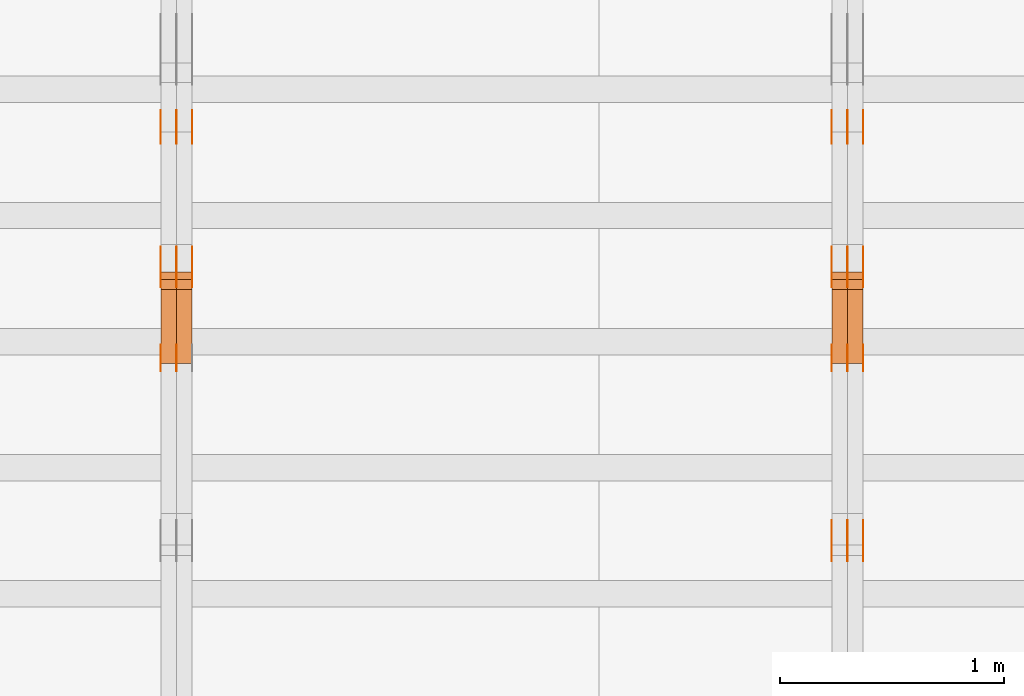
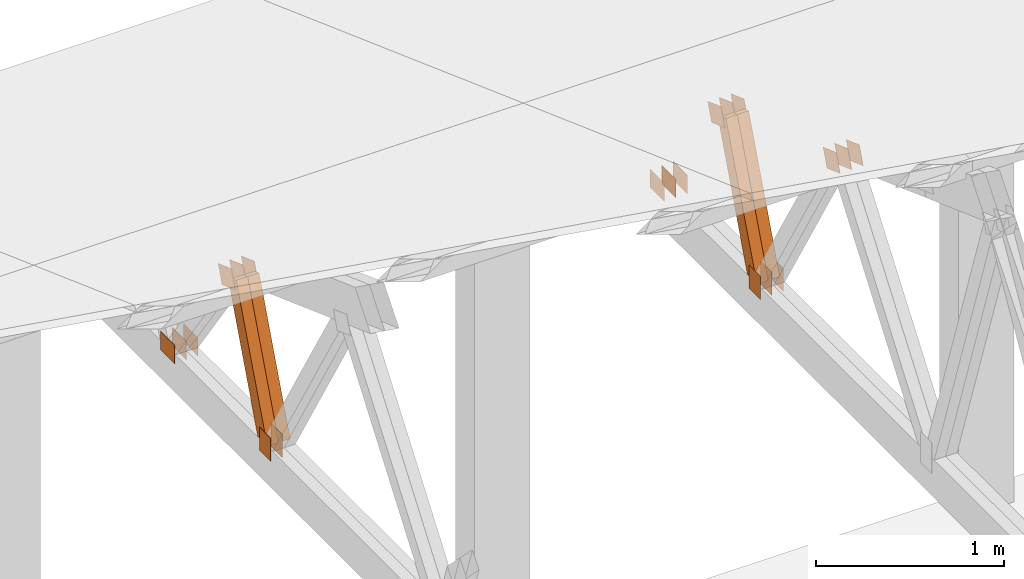
# One storey, part 113 of 189: 31 proxies.
"""IFC2X3 building model written with IfcOpenShell, lengths in millimetres."""

from ifc_helpers import new_model, entity, si_unit, converted_unit, derived_unit, direction, frame, frame_2d, origin, origin_2d_with_axis, place, context, subcontext, project, spatial, polyline, rectangle, outline, extrude, source, transform, mapped, material, type_object, type_shapes, element, save


model = new_model("IFC2X3")

# Units and contexts
model_context = context("Model", 3, precision=0.01, world=origin(), true_north=direction((6.12303176911189e-17, 1.0)))
body_context = subcontext(model_context, "Body", "Model", "MODEL_VIEW")
ifc_project = project(units=[si_unit("LENGTHUNIT", "METRE", prefix="MILLI"), si_unit("AREAUNIT", "SQUARE_METRE"), si_unit("VOLUMEUNIT", "CUBIC_METRE"), converted_unit("PLANEANGLEUNIT", "DEGREE", entity("IfcRatioMeasure", 0.0174532925199433), si_unit("PLANEANGLEUNIT", "RADIAN"), dimensions=[0, 0, 0, 0, 0, 0, 0]), si_unit("MASSUNIT", "GRAM", prefix="KILO"), derived_unit("MASSDENSITYUNIT", [(si_unit("MASSUNIT", "GRAM", prefix="KILO"), 1), (si_unit("LENGTHUNIT", "METRE"), -3)]), si_unit("TIMEUNIT", "SECOND"), si_unit("FREQUENCYUNIT", "HERTZ"), si_unit("THERMODYNAMICTEMPERATUREUNIT", "DEGREE_CELSIUS"), derived_unit("THERMALTRANSMITTANCEUNIT", [(si_unit("MASSUNIT", "GRAM", prefix="KILO"), 1), (si_unit("THERMODYNAMICTEMPERATUREUNIT", "KELVIN"), -1), (si_unit("TIMEUNIT", "SECOND"), -3)]), derived_unit("VOLUMETRICFLOWRATEUNIT", [(si_unit("LENGTHUNIT", "METRE"), 3), (si_unit("TIMEUNIT", "SECOND"), -1)]), si_unit("ELECTRICCURRENTUNIT", "AMPERE"), si_unit("ELECTRICVOLTAGEUNIT", "VOLT"), si_unit("POWERUNIT", "WATT"), si_unit("FORCEUNIT", "NEWTON"), si_unit("ILLUMINANCEUNIT", "LUX"), si_unit("LUMINOUSFLUXUNIT", "LUMEN"), si_unit("LUMINOUSINTENSITYUNIT", "CANDELA"), derived_unit("USERDEFINED", [(si_unit("MASSUNIT", "GRAM", prefix="KILO"), -1), (si_unit("LENGTHUNIT", "METRE"), -2), (si_unit("TIMEUNIT", "SECOND"), 3), (si_unit("LUMINOUSFLUXUNIT", "LUMEN"), 1)]), derived_unit("LINEARVELOCITYUNIT", [(si_unit("LENGTHUNIT", "METRE"), 1), (si_unit("TIMEUNIT", "SECOND"), -1)]), si_unit("PRESSUREUNIT", "PASCAL"), derived_unit("USERDEFINED", [(si_unit("LENGTHUNIT", "METRE"), -2), (si_unit("MASSUNIT", "GRAM", prefix="KILO"), 1), (si_unit("TIMEUNIT", "SECOND"), -2)])], contexts=[model_context])

# Site, building, storey
site_placement = place(None, origin())
site = spatial("IfcSite", under=ifc_project, at=site_placement, CompositionType="ELEMENT")
building_placement = place(site_placement, origin())
building = spatial("IfcBuilding", under=site, at=building_placement, CompositionType="ELEMENT")
storey_placement = place(building_placement, origin())
storey = spatial("IfcBuildingStorey", under=building, at=storey_placement, Name="Default", CompositionType="ELEMENT", Elevation=0.0)

# Proxies
ifc_material_1 = material(Name="IfcSurfaceStyle #42406")
building_element_proxy_type_1 = type_object("IfcBuildingElementProxyType", PredefinedType="NOTDEFINED", material=ifc_material_1)
shared_shape_1 = source(origin(), body_context, "Body", "SweptSolid", [
    extrude(outline(polyline([(-74.9999475298494, -60.0), (75.0000042257432, -60.0), (74.9999684051025, 60.0), (-75.0000251009963, 60.0), (-74.9999475298494, -60.0)])), frame((75.0000607644577, 60.0000865490217, 0.0), z_axis=(0.0, 0.0, 1.0), x_axis=(-1.0, 0.0, 0.0)), (0.0, 0.0, 1.0), 1.3),
])
type_shapes(building_element_proxy_type_1, [shared_shape_1])
proxy_1_placement = place(building_placement, frame((6336.3, 25732.0586805394, 1446.84420669249), z_axis=(-1.0, 0.0, 0.0), x_axis=(0.0, -0.939692620785908, 0.342020143325669)))
element("IfcBuildingElementProxy", 1, at=proxy_1_placement, inside=storey, type_object=building_element_proxy_type_1, material=ifc_material_1, context=body_context, shape_type="MappedRepresentation", body=[
    mapped(shared_shape_1, transform((0.0, 0.0, 0.0), scale=1.0)),
])
ifc_material_2 = material(Name="IfcSurfaceStyle #42349")
building_element_proxy_type_2 = type_object("IfcBuildingElementProxyType", PredefinedType="NOTDEFINED", material=ifc_material_2)
shared_shape_2 = source(origin(), body_context, "Body", "SweptSolid", [
    extrude(outline(polyline([(-74.9999475298494, -60.0), (75.0000042257432, -60.0), (74.9999684051025, 60.0), (-75.0000251009963, 60.0), (-74.9999475298494, -60.0)])), frame((75.0000607644577, 60.0000865490217, 0.0), z_axis=(0.0, 0.0, 1.0), x_axis=(-1.0, 0.0, 0.0)), (0.0, 0.0, 1.0), 1.29999999999999),
])
type_shapes(building_element_proxy_type_2, [shared_shape_2])
proxy_2_placement = place(building_placement, frame((6265.0, 25732.0586805394, 1446.84420669249), z_axis=(-1.0, 0.0, 0.0), x_axis=(0.0, -0.939692620785908, 0.342020143325669)))
element("IfcBuildingElementProxy", 2, at=proxy_2_placement, inside=storey, type_object=building_element_proxy_type_2, material=ifc_material_2, context=body_context, shape_type="MappedRepresentation", body=[
    mapped(shared_shape_2, transform((0.0, 0.0, 0.0), scale=1.0)),
])
ifc_material_3 = material(Name="IfcSurfaceStyle #42292")
building_element_proxy_type_3 = type_object("IfcBuildingElementProxyType", PredefinedType="NOTDEFINED", material=ifc_material_3)
shared_shape_3 = source(origin(), body_context, "Body", "SweptSolid", [
    extrude(outline(polyline([(-74.9999475298494, -60.0), (75.0000042257432, -60.0), (74.9999684051025, 60.0), (-75.0000251009963, 60.0), (-74.9999475298494, -60.0)])), frame((75.0000607644577, 60.0000865490217, 0.0), z_axis=(0.0, 0.0, 1.0), x_axis=(-1.0, 0.0, 0.0)), (0.0, 0.0, 1.0), 1.29999999999999),
])
type_shapes(building_element_proxy_type_3, [shared_shape_3])
proxy_3_placement = place(building_placement, frame((6266.3, 25732.0586805394, 1446.84420669249), z_axis=(-1.0, 0.0, 0.0), x_axis=(0.0, -0.939692620785908, 0.342020143325669)))
element("IfcBuildingElementProxy", 3, at=proxy_3_placement, inside=storey, type_object=building_element_proxy_type_3, material=ifc_material_3, context=body_context, shape_type="MappedRepresentation", body=[
    mapped(shared_shape_3, transform((0.0, 0.0, 0.0), scale=1.0)),
])
ifc_material_4 = material(Name="IfcSurfaceStyle #42235")
building_element_proxy_type_4 = type_object("IfcBuildingElementProxyType", PredefinedType="NOTDEFINED", material=ifc_material_4)
shared_shape_4 = source(origin(), body_context, "Body", "SweptSolid", [
    extrude(outline(polyline([(-74.9999475298494, -60.0), (75.0000042257432, -60.0), (74.9999684051025, 60.0), (-75.0000251009963, 60.0), (-74.9999475298494, -60.0)])), frame((75.0000607644577, 60.0000865490217, 0.0), z_axis=(0.0, 0.0, 1.0), x_axis=(-1.0, 0.0, 0.0)), (0.0, 0.0, 1.0), 1.29999999999999),
])
type_shapes(building_element_proxy_type_4, [shared_shape_4])
proxy_4_placement = place(building_placement, frame((6195.0, 25732.0586805394, 1446.84420669249), z_axis=(-1.0, 0.0, 0.0), x_axis=(0.0, -0.939692620785908, 0.342020143325669)))
element("IfcBuildingElementProxy", 4, at=proxy_4_placement, inside=storey, type_object=building_element_proxy_type_4, material=ifc_material_4, context=body_context, shape_type="MappedRepresentation", body=[
    mapped(shared_shape_4, transform((0.0, 0.0, 0.0), scale=1.0)),
])
ifc_material_5 = material(Name="IfcSurfaceStyle #42178")
building_element_proxy_type_5 = type_object("IfcBuildingElementProxyType", PredefinedType="NOTDEFINED", material=ifc_material_5)
shared_shape_5 = source(origin(), body_context, "Body", "SweptSolid", [
    extrude(rectangle(XDim=150.0, YDim=120.0, at=frame_2d((-7.105427357601e-15, 0.0), x_axis=(1.0, 0.0))), frame((75.0, 60.0, 0.0), z_axis=(0.0, 0.0, 1.0), x_axis=(-1.0, 0.0, 0.0)), (0.0, 0.0, 1.0), 1.3),
])
type_shapes(building_element_proxy_type_5, [shared_shape_5])
proxy_5_placement = place(building_placement, frame((6336.3, 26439.0083007813, 170.0), z_axis=(-1.0, 0.0, 0.0), x_axis=(0.0, 0.0, 1.0)))
element("IfcBuildingElementProxy", 5, at=proxy_5_placement, inside=storey, type_object=building_element_proxy_type_5, material=ifc_material_5, context=body_context, shape_type="MappedRepresentation", body=[
    mapped(shared_shape_5, transform((0.0, 0.0, 0.0), scale=1.0)),
])
ifc_material_6 = material(Name="IfcSurfaceStyle #42121")
building_element_proxy_type_6 = type_object("IfcBuildingElementProxyType", PredefinedType="NOTDEFINED", material=ifc_material_6)
shared_shape_6 = source(origin(), body_context, "Body", "SweptSolid", [
    extrude(rectangle(XDim=150.0, YDim=120.0, at=frame_2d((-7.105427357601e-15, 0.0), x_axis=(1.0, 0.0))), frame((75.0, 60.0, 0.0), z_axis=(0.0, 0.0, 1.0), x_axis=(-1.0, 0.0, 0.0)), (0.0, 0.0, 1.0), 1.29999999999999),
])
type_shapes(building_element_proxy_type_6, [shared_shape_6])
proxy_6_placement = place(building_placement, frame((6265.0, 26439.0083007813, 170.0), z_axis=(-1.0, 0.0, 0.0), x_axis=(0.0, 0.0, 1.0)))
element("IfcBuildingElementProxy", 6, at=proxy_6_placement, inside=storey, type_object=building_element_proxy_type_6, material=ifc_material_6, context=body_context, shape_type="MappedRepresentation", body=[
    mapped(shared_shape_6, transform((0.0, 0.0, 0.0), scale=1.0)),
])
ifc_material_7 = material(Name="IfcSurfaceStyle #42064")
building_element_proxy_type_7 = type_object("IfcBuildingElementProxyType", PredefinedType="NOTDEFINED", material=ifc_material_7)
shared_shape_7 = source(origin(), body_context, "Body", "SweptSolid", [
    extrude(rectangle(XDim=150.0, YDim=120.0, at=frame_2d((-7.105427357601e-15, 0.0), x_axis=(1.0, 0.0))), frame((75.0, 60.0, 0.0), z_axis=(0.0, 0.0, 1.0), x_axis=(-1.0, 0.0, 0.0)), (0.0, 0.0, 1.0), 1.29999999999999),
])
type_shapes(building_element_proxy_type_7, [shared_shape_7])
proxy_7_placement = place(building_placement, frame((6266.3, 26439.0083007813, 170.0), z_axis=(-1.0, 0.0, 0.0), x_axis=(0.0, 0.0, 1.0)))
element("IfcBuildingElementProxy", 7, at=proxy_7_placement, inside=storey, type_object=building_element_proxy_type_7, material=ifc_material_7, context=body_context, shape_type="MappedRepresentation", body=[
    mapped(shared_shape_7, transform((0.0, 0.0, 0.0), scale=1.0)),
])
ifc_material_8 = material(Name="IfcSurfaceStyle #42007")
building_element_proxy_type_8 = type_object("IfcBuildingElementProxyType", PredefinedType="NOTDEFINED", material=ifc_material_8)
shared_shape_8 = source(origin(), body_context, "Body", "SweptSolid", [
    extrude(rectangle(XDim=150.0, YDim=120.0, at=frame_2d((-7.105427357601e-15, 0.0), x_axis=(1.0, 0.0))), frame((75.0, 60.0, 0.0), z_axis=(0.0, 0.0, 1.0), x_axis=(-1.0, 0.0, 0.0)), (0.0, 0.0, 1.0), 1.29999999999999),
])
type_shapes(building_element_proxy_type_8, [shared_shape_8])
proxy_8_placement = place(building_placement, frame((6195.0, 26439.0083007813, 170.0), z_axis=(-1.0, 0.0, 0.0), x_axis=(0.0, 0.0, 1.0)))
element("IfcBuildingElementProxy", 8, at=proxy_8_placement, inside=storey, type_object=building_element_proxy_type_8, material=ifc_material_8, context=body_context, shape_type="MappedRepresentation", body=[
    mapped(shared_shape_8, transform((0.0, 0.0, 0.0), scale=1.0)),
])
ifc_material_9 = material(Name="IfcSurfaceStyle #41494")
building_element_proxy_type_9 = type_object("IfcBuildingElementProxyType", PredefinedType="NOTDEFINED", material=ifc_material_9)
shared_shape_9 = source(origin(), body_context, "Body", "SweptSolid", [
    extrude(outline(polyline([(-74.9999684051023, -60.0), (75.0000251009964, -60.0), (74.9999475298495, 60.0), (-75.0000042257435, 60.0), (-74.9999684051023, -60.0)])), frame((75.0000251009964, 60.0000006265238, 0.0), z_axis=(0.0, 0.0, 1.0), x_axis=(-1.0, 0.0, 0.0)), (0.0, 0.0, 1.0), 1.3),
])
type_shapes(building_element_proxy_type_9, [shared_shape_9])
proxy_9_placement = place(building_placement, frame((6336.3, 26956.490053282, 1001.18769055967), z_axis=(-1.0, 0.0, 0.0), x_axis=(0.0, -0.939692620785908, 0.342020143325669)))
element("IfcBuildingElementProxy", 9, at=proxy_9_placement, inside=storey, type_object=building_element_proxy_type_9, material=ifc_material_9, context=body_context, shape_type="MappedRepresentation", body=[
    mapped(shared_shape_9, transform((0.0, 0.0, 0.0), scale=1.0)),
])
ifc_material_10 = material(Name="IfcSurfaceStyle #41437")
building_element_proxy_type_10 = type_object("IfcBuildingElementProxyType", PredefinedType="NOTDEFINED", material=ifc_material_10)
shared_shape_10 = source(origin(), body_context, "Body", "SweptSolid", [
    extrude(outline(polyline([(-74.9999684051023, -60.0), (75.0000251009964, -60.0), (74.9999475298495, 60.0), (-75.0000042257435, 60.0), (-74.9999684051023, -60.0)])), frame((75.0000251009964, 60.0000006265238, 0.0), z_axis=(0.0, 0.0, 1.0), x_axis=(-1.0, 0.0, 0.0)), (0.0, 0.0, 1.0), 1.29999999999999),
])
type_shapes(building_element_proxy_type_10, [shared_shape_10])
proxy_10_placement = place(building_placement, frame((6265.0, 26956.490053282, 1001.18769055967), z_axis=(-1.0, 0.0, 0.0), x_axis=(0.0, -0.939692620785908, 0.342020143325669)))
element("IfcBuildingElementProxy", 10, at=proxy_10_placement, inside=storey, type_object=building_element_proxy_type_10, material=ifc_material_10, context=body_context, shape_type="MappedRepresentation", body=[
    mapped(shared_shape_10, transform((0.0, 0.0, 0.0), scale=1.0)),
])
ifc_material_11 = material(Name="IfcSurfaceStyle #41380")
building_element_proxy_type_11 = type_object("IfcBuildingElementProxyType", PredefinedType="NOTDEFINED", material=ifc_material_11)
shared_shape_11 = source(origin(), body_context, "Body", "SweptSolid", [
    extrude(outline(polyline([(-74.9999684051023, -60.0), (75.0000251009964, -60.0), (74.9999475298495, 60.0), (-75.0000042257435, 60.0), (-74.9999684051023, -60.0)])), frame((75.0000251009964, 60.0000006265238, 0.0), z_axis=(0.0, 0.0, 1.0), x_axis=(-1.0, 0.0, 0.0)), (0.0, 0.0, 1.0), 1.29999999999999),
])
type_shapes(building_element_proxy_type_11, [shared_shape_11])
proxy_11_placement = place(building_placement, frame((6266.3, 26956.490053282, 1001.18769055967), z_axis=(-1.0, 0.0, 0.0), x_axis=(0.0, -0.939692620785908, 0.342020143325669)))
element("IfcBuildingElementProxy", 11, at=proxy_11_placement, inside=storey, type_object=building_element_proxy_type_11, material=ifc_material_11, context=body_context, shape_type="MappedRepresentation", body=[
    mapped(shared_shape_11, transform((0.0, 0.0, 0.0), scale=1.0)),
])
ifc_material_12 = material(Name="IfcSurfaceStyle #41323")
building_element_proxy_type_12 = type_object("IfcBuildingElementProxyType", PredefinedType="NOTDEFINED", material=ifc_material_12)
shared_shape_12 = source(origin(), body_context, "Body", "SweptSolid", [
    extrude(outline(polyline([(-74.9999684051023, -60.0), (75.0000251009964, -60.0), (74.9999475298495, 60.0), (-75.0000042257435, 60.0), (-74.9999684051023, -60.0)])), frame((75.0000251009964, 60.0000006265238, 0.0), z_axis=(0.0, 0.0, 1.0), x_axis=(-1.0, 0.0, 0.0)), (0.0, 0.0, 1.0), 1.29999999999999),
])
type_shapes(building_element_proxy_type_12, [shared_shape_12])
proxy_12_placement = place(building_placement, frame((6195.0, 26956.490053282, 1001.18769055967), z_axis=(-1.0, 0.0, 0.0), x_axis=(0.0, -0.939692620785908, 0.342020143325669)))
element("IfcBuildingElementProxy", 12, at=proxy_12_placement, inside=storey, type_object=building_element_proxy_type_12, material=ifc_material_12, context=body_context, shape_type="MappedRepresentation", body=[
    mapped(shared_shape_12, transform((0.0, 0.0, 0.0), scale=1.0)),
])
ifc_material_13 = material(Name="IfcSurfaceStyle #41266")
building_element_proxy_type_13 = type_object("IfcBuildingElementProxyType", PredefinedType="NOTDEFINED", material=ifc_material_13)
shared_shape_13 = source(origin(), body_context, "Body", "SweptSolid", [
    extrude(rectangle(XDim=150.0, YDim=120.0, at=origin_2d_with_axis()), frame((75.0, 60.0, 0.0), z_axis=(0.0, 0.0, 1.0), x_axis=(-1.0, 0.0, 0.0)), (0.0, 0.0, 1.0), 1.3),
])
type_shapes(building_element_proxy_type_13, [shared_shape_13])
proxy_13_placement = place(building_placement, frame((6336.3, 27607.3129882813, 185.0), z_axis=(-1.0, 0.0, 0.0), x_axis=(0.0, -1.0, 0.0)))
element("IfcBuildingElementProxy", 13, at=proxy_13_placement, inside=storey, type_object=building_element_proxy_type_13, material=ifc_material_13, context=body_context, shape_type="MappedRepresentation", body=[
    mapped(shared_shape_13, transform((0.0, 0.0, 0.0), scale=1.0)),
])
ifc_material_14 = material(Name="IfcSurfaceStyle #41209")
building_element_proxy_type_14 = type_object("IfcBuildingElementProxyType", PredefinedType="NOTDEFINED", material=ifc_material_14)
shared_shape_14 = source(origin(), body_context, "Body", "SweptSolid", [
    extrude(rectangle(XDim=150.0, YDim=120.0, at=origin_2d_with_axis()), frame((75.0, 60.0, 0.0), z_axis=(0.0, 0.0, 1.0), x_axis=(-1.0, 0.0, 0.0)), (0.0, 0.0, 1.0), 1.29999999999999),
])
type_shapes(building_element_proxy_type_14, [shared_shape_14])
proxy_14_placement = place(building_placement, frame((6265.0, 27607.3129882813, 185.0), z_axis=(-1.0, 0.0, 0.0), x_axis=(0.0, -1.0, 0.0)))
element("IfcBuildingElementProxy", 14, at=proxy_14_placement, inside=storey, type_object=building_element_proxy_type_14, material=ifc_material_14, context=body_context, shape_type="MappedRepresentation", body=[
    mapped(shared_shape_14, transform((0.0, 0.0, 0.0), scale=1.0)),
])
ifc_material_15 = material(Name="IfcSurfaceStyle #41152")
building_element_proxy_type_15 = type_object("IfcBuildingElementProxyType", PredefinedType="NOTDEFINED", material=ifc_material_15)
shared_shape_15 = source(origin(), body_context, "Body", "SweptSolid", [
    extrude(rectangle(XDim=150.0, YDim=120.0, at=origin_2d_with_axis()), frame((75.0, 60.0, 0.0), z_axis=(0.0, 0.0, 1.0), x_axis=(-1.0, 0.0, 0.0)), (0.0, 0.0, 1.0), 1.29999999999999),
])
type_shapes(building_element_proxy_type_15, [shared_shape_15])
proxy_15_placement = place(building_placement, frame((6266.3, 27607.3129882813, 185.0), z_axis=(-1.0, 0.0, 0.0), x_axis=(0.0, -1.0, 0.0)))
element("IfcBuildingElementProxy", 15, at=proxy_15_placement, inside=storey, type_object=building_element_proxy_type_15, material=ifc_material_15, context=body_context, shape_type="MappedRepresentation", body=[
    mapped(shared_shape_15, transform((0.0, 0.0, 0.0), scale=1.0)),
])
ifc_material_16 = material(Name="IfcSurfaceStyle #41095")
building_element_proxy_type_16 = type_object("IfcBuildingElementProxyType", PredefinedType="NOTDEFINED", material=ifc_material_16)
shared_shape_16 = source(origin(), body_context, "Body", "SweptSolid", [
    extrude(rectangle(XDim=150.0, YDim=120.0, at=origin_2d_with_axis()), frame((75.0, 60.0, 0.0), z_axis=(0.0, 0.0, 1.0), x_axis=(-1.0, 0.0, 0.0)), (0.0, 0.0, 1.0), 1.29999999999999),
])
type_shapes(building_element_proxy_type_16, [shared_shape_16])
proxy_16_placement = place(building_placement, frame((6195.0, 27607.3129882813, 185.0), z_axis=(-1.0, 0.0, 0.0), x_axis=(0.0, -1.0, 0.0)))
element("IfcBuildingElementProxy", 16, at=proxy_16_placement, inside=storey, type_object=building_element_proxy_type_16, material=ifc_material_16, context=body_context, shape_type="MappedRepresentation", body=[
    mapped(shared_shape_16, transform((0.0, 0.0, 0.0), scale=1.0)),
])
ifc_material_17 = material(Name="IfcSurfaceStyle #34018")
building_element_proxy_type_17 = type_object("IfcBuildingElementProxyType", Name="T1-W14 34016", PredefinedType="NOTDEFINED", material=ifc_material_17)
shared_shape_17 = source(origin(), body_context, "Body", "SweptSolid", [
    extrude(outline(polyline([(-561.981237417233, -47.499947472121), (373.092610496013, -47.499947472121), (373.679602940405, -4.61719047935016e-05), (341.277449358876, 47.4999705580734), (-526.068425378061, 47.4999705580734), (-561.981237417233, -47.499947472121)])), frame((373.679632439416, 47.500120814091, 0.0), z_axis=(0.0, 0.0, 1.0), x_axis=(-1.0, 0.0, 0.0)), (0.0, 0.0, 1.0), 69.9999999999999),
])
type_shapes(building_element_proxy_type_17, [shared_shape_17])
proxy_17_placement = place(building_placement, frame((6335.0, 26895.4809555667, 1086.61918844835), z_axis=(-1.0, 0.0, 0.0), x_axis=(0.0, -0.353606472447933, -0.935394281916951)))
element("IfcBuildingElementProxy", 17, at=proxy_17_placement, inside=storey, type_object=building_element_proxy_type_17, material=ifc_material_17, Name="T1-W14", context=body_context, shape_type="MappedRepresentation", body=[
    mapped(shared_shape_17, transform((0.0, 0.0, 0.0), scale=1.0)),
])
ifc_material_18 = material(Name="IfcSurfaceStyle #33952")
building_element_proxy_type_18 = type_object("IfcBuildingElementProxyType", Name="T1-W14 33950", PredefinedType="NOTDEFINED", material=ifc_material_18)
shared_shape_18 = source(origin(), body_context, "Body", "SweptSolid", [
    extrude(outline(polyline([(-561.981237417233, -47.499947472121), (373.092610496013, -47.499947472121), (373.679602940405, -4.61719047935016e-05), (341.277449358876, 47.4999705580734), (-526.068425378061, 47.4999705580734), (-561.981237417233, -47.499947472121)])), frame((373.679632439416, 47.500120814091, 0.0), z_axis=(0.0, 0.0, 1.0), x_axis=(-1.0, 0.0, 0.0)), (0.0, 0.0, 1.0), 69.9999999999999),
])
type_shapes(building_element_proxy_type_18, [shared_shape_18])
proxy_18_placement = place(building_placement, frame((6265.0, 26895.4809555667, 1086.61918844835), z_axis=(-1.0, 0.0, 0.0), x_axis=(0.0, -0.353606472447933, -0.935394281916951)))
element("IfcBuildingElementProxy", 18, at=proxy_18_placement, inside=storey, type_object=building_element_proxy_type_18, material=ifc_material_18, Name="T1-W14", context=body_context, shape_type="MappedRepresentation", body=[
    mapped(shared_shape_18, transform((0.0, 0.0, 0.0), scale=1.0)),
])
ifc_material_19 = material(Name="IfcSurfaceStyle #26331")
building_element_proxy_type_19 = type_object("IfcBuildingElementProxyType", PredefinedType="NOTDEFINED", material=ifc_material_19)
shared_shape_19 = source(origin(), body_context, "Body", "SweptSolid", [
    extrude(rectangle(XDim=150.0, YDim=120.0, at=frame_2d((-7.105427357601e-15, 0.0), x_axis=(1.0, 0.0))), frame((75.0, 60.0, 0.0), z_axis=(0.0, 0.0, 1.0), x_axis=(-1.0, 0.0, 0.0)), (0.0, 0.0, 1.0), 1.29999999999999),
])
type_shapes(building_element_proxy_type_19, [shared_shape_19])
proxy_19_placement = place(building_placement, frame((3265.0, 26439.0083007813, 170.0), z_axis=(-1.0, 0.0, 0.0), x_axis=(0.0, 0.0, 1.0)))
element("IfcBuildingElementProxy", 19, at=proxy_19_placement, inside=storey, type_object=building_element_proxy_type_19, material=ifc_material_19, context=body_context, shape_type="MappedRepresentation", body=[
    mapped(shared_shape_19, transform((0.0, 0.0, 0.0), scale=1.0)),
])
ifc_material_20 = material(Name="IfcSurfaceStyle #26274")
building_element_proxy_type_20 = type_object("IfcBuildingElementProxyType", PredefinedType="NOTDEFINED", material=ifc_material_20)
shared_shape_20 = source(origin(), body_context, "Body", "SweptSolid", [
    extrude(rectangle(XDim=150.0, YDim=120.0, at=frame_2d((-7.105427357601e-15, 0.0), x_axis=(1.0, 0.0))), frame((75.0, 60.0, 0.0), z_axis=(0.0, 0.0, 1.0), x_axis=(-1.0, 0.0, 0.0)), (0.0, 0.0, 1.0), 1.29999999999999),
])
type_shapes(building_element_proxy_type_20, [shared_shape_20])
proxy_20_placement = place(building_placement, frame((3266.3, 26439.0083007813, 170.0), z_axis=(-1.0, 0.0, 0.0), x_axis=(0.0, 0.0, 1.0)))
element("IfcBuildingElementProxy", 20, at=proxy_20_placement, inside=storey, type_object=building_element_proxy_type_20, material=ifc_material_20, context=body_context, shape_type="MappedRepresentation", body=[
    mapped(shared_shape_20, transform((0.0, 0.0, 0.0), scale=1.0)),
])
ifc_material_21 = material(Name="IfcSurfaceStyle #26217")
building_element_proxy_type_21 = type_object("IfcBuildingElementProxyType", PredefinedType="NOTDEFINED", material=ifc_material_21)
shared_shape_21 = source(origin(), body_context, "Body", "SweptSolid", [
    extrude(rectangle(XDim=150.0, YDim=120.0, at=frame_2d((-7.105427357601e-15, 0.0), x_axis=(1.0, 0.0))), frame((75.0, 60.0, 0.0), z_axis=(0.0, 0.0, 1.0), x_axis=(-1.0, 0.0, 0.0)), (0.0, 0.0, 1.0), 1.29999999999999),
])
type_shapes(building_element_proxy_type_21, [shared_shape_21])
proxy_21_placement = place(building_placement, frame((3195.0, 26439.0083007813, 170.0), z_axis=(-1.0, 0.0, 0.0), x_axis=(0.0, 0.0, 1.0)))
element("IfcBuildingElementProxy", 21, at=proxy_21_placement, inside=storey, type_object=building_element_proxy_type_21, material=ifc_material_21, context=body_context, shape_type="MappedRepresentation", body=[
    mapped(shared_shape_21, transform((0.0, 0.0, 0.0), scale=1.0)),
])
ifc_material_22 = material(Name="IfcSurfaceStyle #25704")
building_element_proxy_type_22 = type_object("IfcBuildingElementProxyType", PredefinedType="NOTDEFINED", material=ifc_material_22)
shared_shape_22 = source(origin(), body_context, "Body", "SweptSolid", [
    extrude(outline(polyline([(-74.9999684051023, -60.0), (75.0000251009964, -60.0), (74.9999475298495, 60.0), (-75.0000042257435, 60.0), (-74.9999684051023, -60.0)])), frame((75.0000251009964, 60.0000006265238, 0.0), z_axis=(0.0, 0.0, 1.0), x_axis=(-1.0, 0.0, 0.0)), (0.0, 0.0, 1.0), 1.3),
])
type_shapes(building_element_proxy_type_22, [shared_shape_22])
proxy_22_placement = place(building_placement, frame((3336.3, 26956.490053282, 1001.18769055967), z_axis=(-1.0, 0.0, 0.0), x_axis=(0.0, -0.939692620785908, 0.342020143325669)))
element("IfcBuildingElementProxy", 22, at=proxy_22_placement, inside=storey, type_object=building_element_proxy_type_22, material=ifc_material_22, context=body_context, shape_type="MappedRepresentation", body=[
    mapped(shared_shape_22, transform((0.0, 0.0, 0.0), scale=1.0)),
])
ifc_material_23 = material(Name="IfcSurfaceStyle #25647")
building_element_proxy_type_23 = type_object("IfcBuildingElementProxyType", PredefinedType="NOTDEFINED", material=ifc_material_23)
shared_shape_23 = source(origin(), body_context, "Body", "SweptSolid", [
    extrude(outline(polyline([(-74.9999684051023, -60.0), (75.0000251009964, -60.0), (74.9999475298495, 60.0), (-75.0000042257435, 60.0), (-74.9999684051023, -60.0)])), frame((75.0000251009964, 60.0000006265238, 0.0), z_axis=(0.0, 0.0, 1.0), x_axis=(-1.0, 0.0, 0.0)), (0.0, 0.0, 1.0), 1.29999999999999),
])
type_shapes(building_element_proxy_type_23, [shared_shape_23])
proxy_23_placement = place(building_placement, frame((3265.0, 26956.490053282, 1001.18769055967), z_axis=(-1.0, 0.0, 0.0), x_axis=(0.0, -0.939692620785908, 0.342020143325669)))
element("IfcBuildingElementProxy", 23, at=proxy_23_placement, inside=storey, type_object=building_element_proxy_type_23, material=ifc_material_23, context=body_context, shape_type="MappedRepresentation", body=[
    mapped(shared_shape_23, transform((0.0, 0.0, 0.0), scale=1.0)),
])
ifc_material_24 = material(Name="IfcSurfaceStyle #25590")
building_element_proxy_type_24 = type_object("IfcBuildingElementProxyType", PredefinedType="NOTDEFINED", material=ifc_material_24)
shared_shape_24 = source(origin(), body_context, "Body", "SweptSolid", [
    extrude(outline(polyline([(-74.9999684051023, -60.0), (75.0000251009964, -60.0), (74.9999475298495, 60.0), (-75.0000042257435, 60.0), (-74.9999684051023, -60.0)])), frame((75.0000251009964, 60.0000006265238, 0.0), z_axis=(0.0, 0.0, 1.0), x_axis=(-1.0, 0.0, 0.0)), (0.0, 0.0, 1.0), 1.29999999999999),
])
type_shapes(building_element_proxy_type_24, [shared_shape_24])
proxy_24_placement = place(building_placement, frame((3266.3, 26956.490053282, 1001.18769055967), z_axis=(-1.0, 0.0, 0.0), x_axis=(0.0, -0.939692620785908, 0.342020143325669)))
element("IfcBuildingElementProxy", 24, at=proxy_24_placement, inside=storey, type_object=building_element_proxy_type_24, material=ifc_material_24, context=body_context, shape_type="MappedRepresentation", body=[
    mapped(shared_shape_24, transform((0.0, 0.0, 0.0), scale=1.0)),
])
ifc_material_25 = material(Name="IfcSurfaceStyle #25533")
building_element_proxy_type_25 = type_object("IfcBuildingElementProxyType", PredefinedType="NOTDEFINED", material=ifc_material_25)
shared_shape_25 = source(origin(), body_context, "Body", "SweptSolid", [
    extrude(outline(polyline([(-74.9999684051023, -60.0), (75.0000251009964, -60.0), (74.9999475298495, 60.0), (-75.0000042257435, 60.0), (-74.9999684051023, -60.0)])), frame((75.0000251009964, 60.0000006265238, 0.0), z_axis=(0.0, 0.0, 1.0), x_axis=(-1.0, 0.0, 0.0)), (0.0, 0.0, 1.0), 1.29999999999999),
])
type_shapes(building_element_proxy_type_25, [shared_shape_25])
proxy_25_placement = place(building_placement, frame((3195.0, 26956.490053282, 1001.18769055967), z_axis=(-1.0, 0.0, 0.0), x_axis=(0.0, -0.939692620785908, 0.342020143325669)))
element("IfcBuildingElementProxy", 25, at=proxy_25_placement, inside=storey, type_object=building_element_proxy_type_25, material=ifc_material_25, context=body_context, shape_type="MappedRepresentation", body=[
    mapped(shared_shape_25, transform((0.0, 0.0, 0.0), scale=1.0)),
])
ifc_material_26 = material(Name="IfcSurfaceStyle #25476")
building_element_proxy_type_26 = type_object("IfcBuildingElementProxyType", PredefinedType="NOTDEFINED", material=ifc_material_26)
shared_shape_26 = source(origin(), body_context, "Body", "SweptSolid", [
    extrude(rectangle(XDim=150.0, YDim=120.0, at=origin_2d_with_axis()), frame((75.0, 60.0, 0.0), z_axis=(0.0, 0.0, 1.0), x_axis=(-1.0, 0.0, 0.0)), (0.0, 0.0, 1.0), 1.3),
])
type_shapes(building_element_proxy_type_26, [shared_shape_26])
proxy_26_placement = place(building_placement, frame((3336.3, 27607.3129882813, 185.0), z_axis=(-1.0, 0.0, 0.0), x_axis=(0.0, -1.0, 0.0)))
element("IfcBuildingElementProxy", 26, at=proxy_26_placement, inside=storey, type_object=building_element_proxy_type_26, material=ifc_material_26, context=body_context, shape_type="MappedRepresentation", body=[
    mapped(shared_shape_26, transform((0.0, 0.0, 0.0), scale=1.0)),
])
ifc_material_27 = material(Name="IfcSurfaceStyle #25419")
building_element_proxy_type_27 = type_object("IfcBuildingElementProxyType", PredefinedType="NOTDEFINED", material=ifc_material_27)
shared_shape_27 = source(origin(), body_context, "Body", "SweptSolid", [
    extrude(rectangle(XDim=150.0, YDim=120.0, at=origin_2d_with_axis()), frame((75.0, 60.0, 0.0), z_axis=(0.0, 0.0, 1.0), x_axis=(-1.0, 0.0, 0.0)), (0.0, 0.0, 1.0), 1.29999999999999),
])
type_shapes(building_element_proxy_type_27, [shared_shape_27])
proxy_27_placement = place(building_placement, frame((3265.0, 27607.3129882813, 185.0), z_axis=(-1.0, 0.0, 0.0), x_axis=(0.0, -1.0, 0.0)))
element("IfcBuildingElementProxy", 27, at=proxy_27_placement, inside=storey, type_object=building_element_proxy_type_27, material=ifc_material_27, context=body_context, shape_type="MappedRepresentation", body=[
    mapped(shared_shape_27, transform((0.0, 0.0, 0.0), scale=1.0)),
])
ifc_material_28 = material(Name="IfcSurfaceStyle #25362")
building_element_proxy_type_28 = type_object("IfcBuildingElementProxyType", PredefinedType="NOTDEFINED", material=ifc_material_28)
shared_shape_28 = source(origin(), body_context, "Body", "SweptSolid", [
    extrude(rectangle(XDim=150.0, YDim=120.0, at=origin_2d_with_axis()), frame((75.0, 60.0, 0.0), z_axis=(0.0, 0.0, 1.0), x_axis=(-1.0, 0.0, 0.0)), (0.0, 0.0, 1.0), 1.29999999999999),
])
type_shapes(building_element_proxy_type_28, [shared_shape_28])
proxy_28_placement = place(building_placement, frame((3266.3, 27607.3129882813, 185.0), z_axis=(-1.0, 0.0, 0.0), x_axis=(0.0, -1.0, 0.0)))
element("IfcBuildingElementProxy", 28, at=proxy_28_placement, inside=storey, type_object=building_element_proxy_type_28, material=ifc_material_28, context=body_context, shape_type="MappedRepresentation", body=[
    mapped(shared_shape_28, transform((0.0, 0.0, 0.0), scale=1.0)),
])
ifc_material_29 = material(Name="IfcSurfaceStyle #25305")
building_element_proxy_type_29 = type_object("IfcBuildingElementProxyType", PredefinedType="NOTDEFINED", material=ifc_material_29)
shared_shape_29 = source(origin(), body_context, "Body", "SweptSolid", [
    extrude(rectangle(XDim=150.0, YDim=120.0, at=origin_2d_with_axis()), frame((75.0, 60.0, 0.0), z_axis=(0.0, 0.0, 1.0), x_axis=(-1.0, 0.0, 0.0)), (0.0, 0.0, 1.0), 1.29999999999999),
])
type_shapes(building_element_proxy_type_29, [shared_shape_29])
proxy_29_placement = place(building_placement, frame((3195.0, 27607.3129882813, 185.0), z_axis=(-1.0, 0.0, 0.0), x_axis=(0.0, -1.0, 0.0)))
element("IfcBuildingElementProxy", 29, at=proxy_29_placement, inside=storey, type_object=building_element_proxy_type_29, material=ifc_material_29, context=body_context, shape_type="MappedRepresentation", body=[
    mapped(shared_shape_29, transform((0.0, 0.0, 0.0), scale=1.0)),
])
ifc_material_30 = material(Name="IfcSurfaceStyle #18228")
building_element_proxy_type_30 = type_object("IfcBuildingElementProxyType", Name="T1-W14 18226", PredefinedType="NOTDEFINED", material=ifc_material_30)
shared_shape_30 = source(origin(), body_context, "Body", "SweptSolid", [
    extrude(outline(polyline([(-561.981237417233, -47.499947472121), (373.092610496013, -47.499947472121), (373.679602940405, -4.61719047935016e-05), (341.277449358876, 47.4999705580734), (-526.068425378061, 47.4999705580734), (-561.981237417233, -47.499947472121)])), frame((373.679632439416, 47.500120814091, 0.0), z_axis=(0.0, 0.0, 1.0), x_axis=(-1.0, 0.0, 0.0)), (0.0, 0.0, 1.0), 69.9999999999999),
])
type_shapes(building_element_proxy_type_30, [shared_shape_30])
proxy_30_placement = place(building_placement, frame((3335.0, 26895.4809555667, 1086.61918844835), z_axis=(-1.0, 0.0, 0.0), x_axis=(0.0, -0.353606472447933, -0.935394281916951)))
element("IfcBuildingElementProxy", 30, at=proxy_30_placement, inside=storey, type_object=building_element_proxy_type_30, material=ifc_material_30, Name="T1-W14", context=body_context, shape_type="MappedRepresentation", body=[
    mapped(shared_shape_30, transform((0.0, 0.0, 0.0), scale=1.0)),
])
ifc_material_31 = material(Name="IfcSurfaceStyle #18162")
building_element_proxy_type_31 = type_object("IfcBuildingElementProxyType", Name="T1-W14 18160", PredefinedType="NOTDEFINED", material=ifc_material_31)
shared_shape_31 = source(origin(), body_context, "Body", "SweptSolid", [
    extrude(outline(polyline([(-561.981237417233, -47.499947472121), (373.092610496013, -47.499947472121), (373.679602940405, -4.61719047935016e-05), (341.277449358876, 47.4999705580734), (-526.068425378061, 47.4999705580734), (-561.981237417233, -47.499947472121)])), frame((373.679632439416, 47.500120814091, 0.0), z_axis=(0.0, 0.0, 1.0), x_axis=(-1.0, 0.0, 0.0)), (0.0, 0.0, 1.0), 69.9999999999999),
])
type_shapes(building_element_proxy_type_31, [shared_shape_31])
proxy_31_placement = place(building_placement, frame((3265.0, 26895.4809555667, 1086.61918844835), z_axis=(-1.0, 0.0, 0.0), x_axis=(0.0, -0.353606472447933, -0.935394281916951)))
element("IfcBuildingElementProxy", 31, at=proxy_31_placement, inside=storey, type_object=building_element_proxy_type_31, material=ifc_material_31, Name="T1-W14", context=body_context, shape_type="MappedRepresentation", body=[
    mapped(shared_shape_31, transform((0.0, 0.0, 0.0), scale=1.0)),
])

save(model, "model.ifc")
